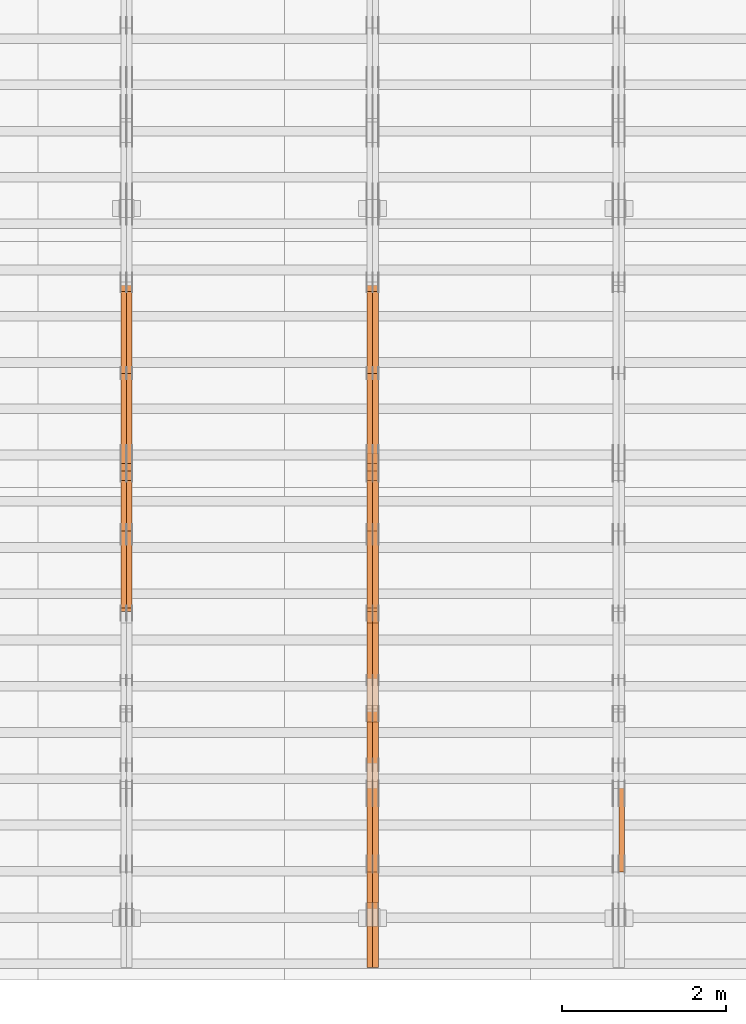
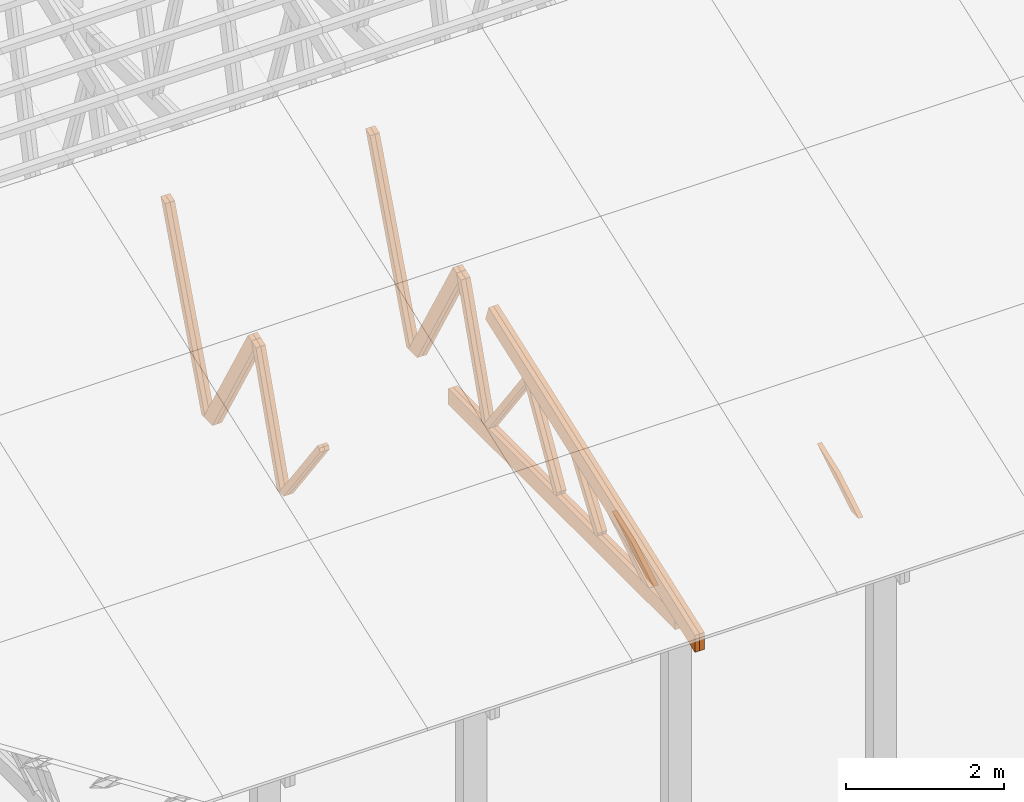
# One storey, part 46 of 189: 27 proxies.
"""IFC2X3 building model written with IfcOpenShell, lengths in millimetres."""

import ifcopenshell
import ifcopenshell.guid

model = None  # the IFC model being written
_history = None  # IfcOwnerHistory: only IFC2X3 demands one
_inside = {}  # id of a spatial element -> (the spatial element, [elements in it])
_under = {}  # id of a project, library or spatial element -> (it, [spatial elements below it])
_declared = {}  # id of a project -> (the project, [libraries it declares])
_typed = {}  # id of a type object -> (the type object, [elements of that type])
_made_of = {}  # id of a material, layer set ... -> (it, [elements and type objects made of it])


def new_model(schema):
    """Start an empty IFC model of exactly this schema.

    Asked for "IFC4X3", IfcOpenShell would pick the latest addendum, in which some entities
    have other attributes; the version numbers below select the first issue.
    IFC2X3 requires an IfcOwnerHistory on every rooted entity: one is made here for all.
    """
    global model, _history
    if schema == "IFC4X3":
        model = ifcopenshell.file(schema_version=(4, 3, 0, 0))
    else:
        model = ifcopenshell.file(schema=schema)
    _inside.clear()
    _under.clear()
    _declared.clear()
    _typed.clear()
    _made_of.clear()
    _history = None
    if model.schema == "IFC2X3":
        org = make("IfcOrganization", Name="unknown")
        user = make(
            "IfcPersonAndOrganization",
            ThePerson=make("IfcPerson", FamilyName="unknown"),
            TheOrganization=org,
        )
        app = make(
            "IfcApplication",
            ApplicationDeveloper=org,
            Version="unknown",
            ApplicationFullName="unknown",
            ApplicationIdentifier="unknown",
        )
        _history = make(
            "IfcOwnerHistory",
            OwningUser=user,
            OwningApplication=app,
            ChangeAction="ADDED",
            CreationDate=0,
        )
    return model


def make(cls, **values):
    """One entity of the class cls with the attributes given. An attribute that is None is left unset."""
    return model.create_entity(
        cls, **{name: value for name, value in values.items() if value is not None}
    )


def entity(cls, *values):
    """Any entity or typed value of the class cls, its attributes in the order of the schema. None: left unset."""
    e = model.create_entity(cls)
    for i, value in enumerate(values):
        if value is not None:
            e[i] = value
    return e


def rooted(cls, **values):
    """An entity with a GlobalId (a new one), such as an element, a storey or a relation."""
    return make(cls, GlobalId=ifcopenshell.guid.new(), OwnerHistory=_history, **values)


def si_unit(unit_type, name, prefix=None):
    """IfcSIUnit, for example si_unit("LENGTHUNIT", "METRE", prefix="MILLI")."""
    return make("IfcSIUnit", UnitType=unit_type, Prefix=prefix, Name=name)


def converted_unit(unit_type, name, factor, base, dimensions=None, offset=None):
    """IfcConversionBasedUnit, such as the inch: factor (a typed value) times the base unit."""
    return make(
        "IfcConversionBasedUnit"
        if offset is None
        else "IfcConversionBasedUnitWithOffset",
        ConversionOffset=offset,
        Dimensions=None
        if dimensions is None
        else entity("IfcDimensionalExponents", *dimensions),
        UnitType=unit_type,
        Name=name,
        ConversionFactor=make(
            "IfcMeasureWithUnit", ValueComponent=factor, UnitComponent=base
        ),
    )


def derived_unit(unit_type, elements):
    """IfcDerivedUnit: a product of units, each with its exponent."""
    return make(
        "IfcDerivedUnit",
        Elements=[
            make("IfcDerivedUnitElement", Unit=unit, Exponent=power)
            for unit, power in elements
        ],
        UnitType=unit_type,
    )


def assignment(units):
    """IfcUnitAssignment: the units of a project."""
    return None if units is None else make("IfcUnitAssignment", Units=units)


def point(xyz):
    """IfcCartesianPoint."""
    return None if xyz is None else make("IfcCartesianPoint", Coordinates=xyz)


def direction(xyz):
    """IfcDirection."""
    return None if xyz is None else make("IfcDirection", DirectionRatios=xyz)


def frame(location, z_axis=None, x_axis=None):
    """IfcAxis2Placement3D, a coordinate frame: its origin and axes. An axis left out is left unset."""
    return make(
        "IfcAxis2Placement3D",
        Location=point(location),
        Axis=direction(z_axis),
        RefDirection=direction(x_axis),
    )


def origin():
    """The frame at (0, 0, 0) with its axes left unset."""
    return frame((0.0, 0.0, 0.0))


def place(relative_to, where):
    """IfcLocalPlacement: puts the frame where relative to a parent placement (None: the world)."""
    return make(
        "IfcLocalPlacement", PlacementRelTo=relative_to, RelativePlacement=where
    )


def context(
    kind, dimensions, precision=None, world=None, true_north=None, identifier=None
):
    """IfcGeometricRepresentationContext, for example the 3D "Model" context."""
    return make(
        "IfcGeometricRepresentationContext",
        ContextIdentifier=identifier,
        ContextType=kind,
        CoordinateSpaceDimension=dimensions,
        Precision=precision,
        WorldCoordinateSystem=world,
        TrueNorth=true_north,
    )


def subcontext(parent, identifier, kind, view, scale=None):
    """IfcGeometricRepresentationSubContext, for example "Body" below "Model"."""
    return make(
        "IfcGeometricRepresentationSubContext",
        ContextIdentifier=identifier,
        ContextType=kind,
        ParentContext=parent,
        TargetScale=scale,
        TargetView=view,
    )


def project(units=None, contexts=None):
    """IfcProject with its units and contexts."""
    return rooted(
        "IfcProject",
        Name="project",
        RepresentationContexts=contexts,
        UnitsInContext=assignment(units),
    )


def spatial(cls, under=None, at=None, **own):
    """A site, building, storey or space (cls), placed at a placement, below another one or the project."""
    s = rooted(cls, ObjectPlacement=at, **own)
    if under is not None:
        _under.setdefault(under.id(), (under, []))[1].append(s)
    return s


def polyline(points):
    """IfcPolyline through the points."""
    return make("IfcPolyline", Points=[point(p) for p in points])


def outline(outer, holes=None, kind="AREA"):
    """IfcArbitraryClosedProfileDef: a profile drawn as a closed curve; with holes, ...WithVoids."""
    if holes is None:
        return make("IfcArbitraryClosedProfileDef", ProfileType=kind, OuterCurve=outer)
    return make(
        "IfcArbitraryProfileDefWithVoids",
        ProfileType=kind,
        OuterCurve=outer,
        InnerCurves=holes,
    )


def extrude(swept, where, along, depth):
    """IfcExtrudedAreaSolid: the profile swept, set in the frame where, extruded along a direction by depth."""
    return make(
        "IfcExtrudedAreaSolid",
        SweptArea=swept,
        Position=where,
        ExtrudedDirection=direction(along),
        Depth=depth,
    )


def shape(context_of_items, identifier, shape_type, items):
    """IfcShapeRepresentation: the items that make up one representation, for example the "Body"."""
    return make(
        "IfcShapeRepresentation",
        ContextOfItems=context_of_items,
        RepresentationIdentifier=identifier,
        RepresentationType=shape_type,
        Items=items,
    )


def source(mapping_origin, context_of_items, identifier, shape_type, items):
    """IfcRepresentationMap: a shape defined once, which mapped items show again and again."""
    return make(
        "IfcRepresentationMap",
        MappingOrigin=mapping_origin,
        MappedRepresentation=shape(context_of_items, identifier, shape_type, items),
    )


def transform(
    local_origin,
    x_axis=None,
    y_axis=None,
    z_axis=None,
    scale=None,
    scale2=None,
    scale3=None,
    uniform=True,
):
    """IfcCartesianTransformationOperator3D, or its non-uniform kind. x_axis, y_axis, z_axis: its Axis1, 2, 3."""
    if uniform:
        return make(
            "IfcCartesianTransformationOperator3D",
            Axis1=direction(x_axis),
            Axis2=direction(y_axis),
            LocalOrigin=point(local_origin),
            Scale=scale,
            Axis3=direction(z_axis),
        )
    return make(
        "IfcCartesianTransformationOperator3DnonUniform",
        Axis1=direction(x_axis),
        Axis2=direction(y_axis),
        LocalOrigin=point(local_origin),
        Scale=scale,
        Axis3=direction(z_axis),
        Scale2=scale2,
        Scale3=scale3,
    )


def mapped(mapping_source, mapping_target):
    """IfcMappedItem: shows the shape of a source again, moved by a transform."""
    return make(
        "IfcMappedItem", MappingSource=mapping_source, MappingTarget=mapping_target
    )


def material(Name=None, Category=None):
    """IfcMaterial."""
    return make("IfcMaterial", Name=Name, Category=Category)


def made_of(thing, what):
    """Note that an element or type object is made of a material, layer set ...; save() writes the relation."""
    if what is not None:
        _made_of.setdefault(what.id(), (what, []))[1].append(thing)
    return thing


def type_object(cls, material=None, **own):
    """A type object (cls), such as IfcWallType, which elements share."""
    return made_of(rooted(cls, **own), material)


def type_shapes(of_type, sources):
    """Give a type object the sources (RepresentationMaps) that its elements show as mapped items."""
    of_type.RepresentationMaps = sources


def element(
    cls,
    number,
    at=None,
    inside=None,
    cuts=None,
    type_object=None,
    material=None,
    context=None,
    identifier="Body",
    shape_type=None,
    held_by="IfcProductDefinitionShape",
    body=None,
    shapes=None,
    **own,
):
    """One element of the class cls, such as IfcWall. Its Tag is "e" and its number.

    at: its placement. inside: the storey or other place that contains it. cuts: it is an
    opening in that element (IfcRelVoidsElement). A single representation is given by context,
    identifier, shape_type and body (its items); several are given by shapes. held_by: the class
    of the entity that holds the representations. save() writes the other relations.
    """
    e = rooted(cls, Tag="e%d" % number, ObjectPlacement=at, **own)
    if body is not None:
        shapes = [shape(context, identifier, shape_type, body)]
    if shapes is not None:
        e.Representation = make(held_by, Representations=shapes)
    if inside is not None:
        _inside.setdefault(inside.id(), (inside, []))[1].append(e)
    if cuts is not None:
        rooted(
            "IfcRelVoidsElement", RelatingBuildingElement=cuts, RelatedOpeningElement=e
        )
    if type_object is not None:
        _typed.setdefault(type_object.id(), (type_object, []))[1].append(e)
    return made_of(e, material)


def aggregate(whole, parts):
    """IfcRelAggregates: a whole, such as a stair, and the parts it consists of."""
    return rooted("IfcRelAggregates", RelatingObject=whole, RelatedObjects=parts)


def save(model, path):
    """Write the relations noted so far, then the file.

    IfcRelAggregates (storeys below a building ...), IfcRelContainedInSpatialStructure (elements
    in a storey), IfcRelDefinesByType, IfcRelAssociatesMaterial and IfcRelDeclares: one each for
    every whole, place, type object, material and project.
    """
    for whole, parts in _under.values():
        aggregate(whole, parts)
    for where, things in _inside.values():
        rooted(
            "IfcRelContainedInSpatialStructure",
            RelatedElements=things,
            RelatingStructure=where,
        )
    for kind, things in _typed.values():
        rooted("IfcRelDefinesByType", RelatedObjects=things, RelatingType=kind)
    for what, things in _made_of.values():
        rooted("IfcRelAssociatesMaterial", RelatedObjects=things, RelatingMaterial=what)
    for by, libraries in _declared.values():
        rooted("IfcRelDeclares", RelatingContext=by, RelatedDefinitions=libraries)
    model.write(path)


model = new_model("IFC2X3")

# Units and contexts
model_context = context("Model", 3, precision=0.01, world=origin(), true_north=direction((6.12303176911189e-17, 1.0)))
body_context = subcontext(model_context, "Body", "Model", "MODEL_VIEW")
ifc_project = project(units=[si_unit("LENGTHUNIT", "METRE", prefix="MILLI"), si_unit("AREAUNIT", "SQUARE_METRE"), si_unit("VOLUMEUNIT", "CUBIC_METRE"), converted_unit("PLANEANGLEUNIT", "DEGREE", entity("IfcRatioMeasure", 0.0174532925199433), si_unit("PLANEANGLEUNIT", "RADIAN"), dimensions=[0, 0, 0, 0, 0, 0, 0]), si_unit("MASSUNIT", "GRAM", prefix="KILO"), derived_unit("MASSDENSITYUNIT", [(si_unit("MASSUNIT", "GRAM", prefix="KILO"), 1), (si_unit("LENGTHUNIT", "METRE"), -3)]), si_unit("TIMEUNIT", "SECOND"), si_unit("FREQUENCYUNIT", "HERTZ"), si_unit("THERMODYNAMICTEMPERATUREUNIT", "DEGREE_CELSIUS"), derived_unit("THERMALTRANSMITTANCEUNIT", [(si_unit("MASSUNIT", "GRAM", prefix="KILO"), 1), (si_unit("THERMODYNAMICTEMPERATUREUNIT", "KELVIN"), -1), (si_unit("TIMEUNIT", "SECOND"), -3)]), derived_unit("VOLUMETRICFLOWRATEUNIT", [(si_unit("LENGTHUNIT", "METRE"), 3), (si_unit("TIMEUNIT", "SECOND"), -1)]), si_unit("ELECTRICCURRENTUNIT", "AMPERE"), si_unit("ELECTRICVOLTAGEUNIT", "VOLT"), si_unit("POWERUNIT", "WATT"), si_unit("FORCEUNIT", "NEWTON"), si_unit("ILLUMINANCEUNIT", "LUX"), si_unit("LUMINOUSFLUXUNIT", "LUMEN"), si_unit("LUMINOUSINTENSITYUNIT", "CANDELA"), derived_unit("USERDEFINED", [(si_unit("MASSUNIT", "GRAM", prefix="KILO"), -1), (si_unit("LENGTHUNIT", "METRE"), -2), (si_unit("TIMEUNIT", "SECOND"), 3), (si_unit("LUMINOUSFLUXUNIT", "LUMEN"), 1)]), derived_unit("LINEARVELOCITYUNIT", [(si_unit("LENGTHUNIT", "METRE"), 1), (si_unit("TIMEUNIT", "SECOND"), -1)]), si_unit("PRESSUREUNIT", "PASCAL"), derived_unit("USERDEFINED", [(si_unit("LENGTHUNIT", "METRE"), -2), (si_unit("MASSUNIT", "GRAM", prefix="KILO"), 1), (si_unit("TIMEUNIT", "SECOND"), -2)])], contexts=[model_context])

# Site, building, storey
site_placement = place(None, origin())
site = spatial("IfcSite", under=ifc_project, at=site_placement, CompositionType="ELEMENT")
building_placement = place(site_placement, origin())
building = spatial("IfcBuilding", under=site, at=building_placement, CompositionType="ELEMENT")
storey_placement = place(building_placement, origin())
storey = spatial("IfcBuildingStorey", under=building, at=storey_placement, Name="Default", CompositionType="ELEMENT", Elevation=0.0)

# Proxies
ifc_material_1 = material(Name="IfcSurfaceStyle #207048")
building_element_proxy_type_1 = type_object("IfcBuildingElementProxyType", Name="T1-W12 207046", PredefinedType="NOTDEFINED", material=ifc_material_1)
shared_shape_1 = source(origin(), body_context, "Body", "SweptSolid", [
    extrude(outline(polyline([(-671.888430889784, -47.499785620702), (344.892972119224, -47.499785620702), (503.856463083211, 47.4997856207019), (-176.861004312651, 47.499785620702), (-671.888430889784, -47.499785620702)])), frame((503.857114243549, 47.5002636410509, 0.0), z_axis=(0.0, 0.0, 1.0), x_axis=(-1.0, 0.0, 0.0)), (0.0, 0.0, 1.0), 69.9999999999999),
])
type_shapes(building_element_proxy_type_1, [shared_shape_1])
proxy_1_placement = place(building_placement, frame((39300.0, 665.58122707747, 245.000076287477), z_axis=(-1.0, 0.0, 0.0), x_axis=(0.0, 0.858392121304013, 0.51299411895576)))
element("IfcBuildingElementProxy", 1, at=proxy_1_placement, inside=storey, type_object=building_element_proxy_type_1, material=ifc_material_1, Name="T1-W12", context=body_context, shape_type="MappedRepresentation", body=[
    mapped(shared_shape_1, transform((0.0, 0.0, 0.0), scale=1.0)),
])
ifc_material_2 = material(Name="IfcSurfaceStyle #193370")
building_element_proxy_type_2 = type_object("IfcBuildingElementProxyType", Name="T1-W8 193368", PredefinedType="NOTDEFINED", material=ifc_material_2)
shared_shape_2 = source(origin(), body_context, "Body", "SweptSolid", [
    extrude(outline(polyline([(-1781.70529904483, -47.500320228718), (1161.65050357787, -47.5003202287179), (1179.56135870849, 0.000731866266039397), (1140.6022069428, 47.4998218997103), (-1700.10877018433, 47.5000866914596), (-1781.70529904483, -47.500320228718)])), frame((1179.56135870869, 47.5007236522113, 0.0), z_axis=(0.0, 0.0, 1.0), x_axis=(-1.0, 3.74658825645258e-07, 0.0)), (0.0, 0.0, 1.0), 69.9999999999998),
])
type_shapes(building_element_proxy_type_2, [shared_shape_2])
proxy_2_placement = place(building_placement, frame((36300.0, 6723.5697965901, 261.758864533503), z_axis=(-1.0, 0.0, 0.0), x_axis=(0.0, 0.352814979177603, 0.93569310698963)))
element("IfcBuildingElementProxy", 2, at=proxy_2_placement, inside=storey, type_object=building_element_proxy_type_2, material=ifc_material_2, Name="T1-W8", context=body_context, shape_type="MappedRepresentation", body=[
    mapped(shared_shape_2, transform((0.0, 0.0, 0.0), scale=1.0)),
])
ifc_material_3 = material(Name="IfcSurfaceStyle #193304")
building_element_proxy_type_3 = type_object("IfcBuildingElementProxyType", Name="T1-W8 193302", PredefinedType="NOTDEFINED", material=ifc_material_3)
shared_shape_3 = source(origin(), body_context, "Body", "SweptSolid", [
    extrude(outline(polyline([(-1781.70529904483, -47.500320228718), (1161.65050357787, -47.5003202287179), (1179.56135870849, 0.000731866266039397), (1140.6022069428, 47.4998218997103), (-1700.10877018433, 47.5000866914596), (-1781.70529904483, -47.500320228718)])), frame((1179.56135870869, 47.5007236522113, 0.0), z_axis=(0.0, 0.0, 1.0), x_axis=(-1.0, 3.74658825645258e-07, 0.0)), (0.0, 0.0, 1.0), 69.9999999999998),
])
type_shapes(building_element_proxy_type_3, [shared_shape_3])
proxy_3_placement = place(building_placement, frame((36230.0, 6723.5697965901, 261.758864533503), z_axis=(-1.0, 0.0, 0.0), x_axis=(0.0, 0.352814979177603, 0.93569310698963)))
element("IfcBuildingElementProxy", 3, at=proxy_3_placement, inside=storey, type_object=building_element_proxy_type_3, material=ifc_material_3, Name="T1-W8", context=body_context, shape_type="MappedRepresentation", body=[
    mapped(shared_shape_3, transform((0.0, 0.0, 0.0), scale=1.0)),
])
ifc_material_4 = material(Name="IfcSurfaceStyle #193106")
building_element_proxy_type_4 = type_object("IfcBuildingElementProxyType", Name="T1-W2 193104", PredefinedType="NOTDEFINED", material=ifc_material_4)
shared_shape_4 = source(origin(), body_context, "Body", "SweptSolid", [
    extrude(outline(polyline([(-765.033104991319, -1130.91940266317), (-539.905732758898, -1130.91940266317), (493.678280567457, 660.584515081422), (452.144945212405, 783.697385511457), (359.115611970356, 817.556904733455), (-765.033104991319, -1130.91940266317)])), frame((904.774360566371, 97.5002668805543, 0.0), z_axis=(0.0, 0.0, 1.0), x_axis=(-0.499731715721184, 0.866180242387438, 0.0)), (0.0, 0.0, 1.0), 69.9999999999998),
])
type_shapes(building_element_proxy_type_4, [shared_shape_4])
proxy_4_placement = place(building_placement, frame((36300.0, 5635.28919163287, 2208.3400784451), z_axis=(-1.0, 0.0, 0.0), x_axis=(0.0, 0.5, -0.866025403784439)))
element("IfcBuildingElementProxy", 4, at=proxy_4_placement, inside=storey, type_object=building_element_proxy_type_4, material=ifc_material_4, Name="T1-W2", context=body_context, shape_type="MappedRepresentation", body=[
    mapped(shared_shape_4, transform((0.0, 0.0, 0.0), scale=1.0)),
])
ifc_material_5 = material(Name="IfcSurfaceStyle #193040")
building_element_proxy_type_5 = type_object("IfcBuildingElementProxyType", Name="T1-W2 193038", PredefinedType="NOTDEFINED", material=ifc_material_5)
shared_shape_5 = source(origin(), body_context, "Body", "SweptSolid", [
    extrude(outline(polyline([(-765.033104991319, -1130.91940266317), (-539.905732758898, -1130.91940266317), (493.678280567457, 660.584515081422), (452.144945212405, 783.697385511457), (359.115611970356, 817.556904733455), (-765.033104991319, -1130.91940266317)])), frame((904.774360566371, 97.5002668805543, 0.0), z_axis=(0.0, 0.0, 1.0), x_axis=(-0.499731715721184, 0.866180242387438, 0.0)), (0.0, 0.0, 1.0), 69.9999999999998),
])
type_shapes(building_element_proxy_type_5, [shared_shape_5])
proxy_5_placement = place(building_placement, frame((36230.0, 5635.28919163287, 2208.3400784451), z_axis=(-1.0, 0.0, 0.0), x_axis=(0.0, 0.5, -0.866025403784439)))
element("IfcBuildingElementProxy", 5, at=proxy_5_placement, inside=storey, type_object=building_element_proxy_type_5, material=ifc_material_5, Name="T1-W2", context=body_context, shape_type="MappedRepresentation", body=[
    mapped(shared_shape_5, transform((0.0, 0.0, 0.0), scale=1.0)),
])
ifc_material_6 = material(Name="IfcSurfaceStyle #192842")
building_element_proxy_type_6 = type_object("IfcBuildingElementProxyType", Name="T1-W9 192840", PredefinedType="NOTDEFINED", material=ifc_material_6)
shared_shape_6 = source(origin(), body_context, "Body", "SweptSolid", [
    extrude(outline(polyline([(-1227.3969292634, -47.5000382896404), (793.242467803064, -47.5000382896404), (809.267705296822, 1.0956605530188e-05), (776.329919980315, 47.5000328113376), (-1151.4431638168, 47.5000328113376), (-1227.3969292634, -47.5000382896404)])), frame((809.267705296822, 47.5000328113376, 0.0), z_axis=(0.0, 0.0, 1.0), x_axis=(-1.0, 0.0, 0.0)), (0.0, 0.0, 1.0), 69.9999999999999),
])
type_shapes(building_element_proxy_type_6, [shared_shape_6])
proxy_6_placement = place(building_placement, frame((36300.0, 4809.76380889125, 260.184242613649), z_axis=(-1.0, 0.0, 0.0), x_axis=(0.0, 0.31966811847134, 0.947529574226047)))
element("IfcBuildingElementProxy", 6, at=proxy_6_placement, inside=storey, type_object=building_element_proxy_type_6, material=ifc_material_6, Name="T1-W9", context=body_context, shape_type="MappedRepresentation", body=[
    mapped(shared_shape_6, transform((0.0, 0.0, 0.0), scale=1.0)),
])
ifc_material_7 = material(Name="IfcSurfaceStyle #192776")
building_element_proxy_type_7 = type_object("IfcBuildingElementProxyType", Name="T1-W9 192774", PredefinedType="NOTDEFINED", material=ifc_material_7)
shared_shape_7 = source(origin(), body_context, "Body", "SweptSolid", [
    extrude(outline(polyline([(-1227.3969292634, -47.5000382896404), (793.242467803064, -47.5000382896404), (809.267705296822, 1.0956605530188e-05), (776.329919980315, 47.5000328113376), (-1151.4431638168, 47.5000328113376), (-1227.3969292634, -47.5000382896404)])), frame((809.267705296822, 47.5000328113376, 0.0), z_axis=(0.0, 0.0, 1.0), x_axis=(-1.0, 0.0, 0.0)), (0.0, 0.0, 1.0), 69.9999999999999),
])
type_shapes(building_element_proxy_type_7, [shared_shape_7])
proxy_7_placement = place(building_placement, frame((36230.0, 4809.76380889125, 260.184242613649), z_axis=(-1.0, 0.0, 0.0), x_axis=(0.0, 0.31966811847134, 0.947529574226047)))
element("IfcBuildingElementProxy", 7, at=proxy_7_placement, inside=storey, type_object=building_element_proxy_type_7, material=ifc_material_7, Name="T1-W9", context=body_context, shape_type="MappedRepresentation", body=[
    mapped(shared_shape_7, transform((0.0, 0.0, 0.0), scale=1.0)),
])
ifc_material_8 = material(Name="IfcSurfaceStyle #192578")
building_element_proxy_type_8 = type_object("IfcBuildingElementProxyType", Name="T1-W10 192576", PredefinedType="NOTDEFINED", material=ifc_material_8)
shared_shape_8 = source(origin(), body_context, "Body", "SweptSolid", [
    extrude(outline(polyline([(-922.639472665691, -47.5001890573134), (629.920966338637, -47.5001890573134), (650.067737483374, 0.000694680531158376), (635.89112756682, 47.4998417170478), (-993.240358723139, 47.4998417170478), (-922.639472665691, -47.5001890573134)])), frame((650.068202545693, 47.4999816623145, 0.0), z_axis=(0.0, 0.0, 1.0), x_axis=(-1.0, 0.0, 0.0)), (0.0, 0.0, 1.0), 69.9999999999999),
])
type_shapes(building_element_proxy_type_8, [shared_shape_8])
proxy_8_placement = place(building_placement, frame((36300.0, 3874.56126239818, 1563.95828147518), z_axis=(-1.0, 0.0, 0.0), x_axis=(0.0, 0.596486092002, -0.802623412347398)))
element("IfcBuildingElementProxy", 8, at=proxy_8_placement, inside=storey, type_object=building_element_proxy_type_8, material=ifc_material_8, Name="T1-W10", context=body_context, shape_type="MappedRepresentation", body=[
    mapped(shared_shape_8, transform((0.0, 0.0, 0.0), scale=1.0)),
])
ifc_material_9 = material(Name="IfcSurfaceStyle #192512")
building_element_proxy_type_9 = type_object("IfcBuildingElementProxyType", Name="T1-W10 192510", PredefinedType="NOTDEFINED", material=ifc_material_9)
shared_shape_9 = source(origin(), body_context, "Body", "SweptSolid", [
    extrude(outline(polyline([(-922.639472665691, -47.5001890573134), (629.920966338637, -47.5001890573134), (650.067737483374, 0.000694680531158376), (635.89112756682, 47.4998417170478), (-993.240358723139, 47.4998417170478), (-922.639472665691, -47.5001890573134)])), frame((650.068202545693, 47.4999816623145, 0.0), z_axis=(0.0, 0.0, 1.0), x_axis=(-1.0, 0.0, 0.0)), (0.0, 0.0, 1.0), 69.9999999999999),
])
type_shapes(building_element_proxy_type_9, [shared_shape_9])
proxy_9_placement = place(building_placement, frame((36230.0, 3874.56126239818, 1563.95828147518), z_axis=(-1.0, 0.0, 0.0), x_axis=(0.0, 0.596486092002, -0.802623412347398)))
element("IfcBuildingElementProxy", 9, at=proxy_9_placement, inside=storey, type_object=building_element_proxy_type_9, material=ifc_material_9, Name="T1-W10", context=body_context, shape_type="MappedRepresentation", body=[
    mapped(shared_shape_9, transform((0.0, 0.0, 0.0), scale=1.0)),
])
ifc_material_10 = material(Name="IfcSurfaceStyle #192314")
building_element_proxy_type_10 = type_object("IfcBuildingElementProxyType", Name="T1-W11 192312", PredefinedType="NOTDEFINED", material=ifc_material_10)
shared_shape_10 = source(origin(), body_context, "Body", "SweptSolid", [
    extrude(outline(polyline([(593.358012843793, -552.565239103314), (742.388662259985, -552.565239103314), (-410.498749190676, 401.275038694583), (-462.246133468927, 382.44069706518), (-463.001792444175, 321.414742446865), (593.358012843793, -552.565239103314)])), frame((599.94412413079, 47.5003788877286, 0.0), z_axis=(0.0, 0.0, 1.0), x_axis=(0.770483455324544, 0.637459994879013, 0.0)), (0.0, 0.0, 1.0), 69.9999999999999),
])
type_shapes(building_element_proxy_type_10, [shared_shape_10])
proxy_10_placement = place(building_placement, frame((36300.0, 2983.26655629375, 269.034992751429), z_axis=(-1.0, 0.0, 0.0), x_axis=(0.0, 0.505995901100606, 0.862535882192379)))
element("IfcBuildingElementProxy", 10, at=proxy_10_placement, inside=storey, type_object=building_element_proxy_type_10, material=ifc_material_10, Name="T1-W11", context=body_context, shape_type="MappedRepresentation", body=[
    mapped(shared_shape_10, transform((0.0, 0.0, 0.0), scale=1.0)),
])
ifc_material_11 = material(Name="IfcSurfaceStyle #192248")
building_element_proxy_type_11 = type_object("IfcBuildingElementProxyType", Name="T1-W11 192246", PredefinedType="NOTDEFINED", material=ifc_material_11)
shared_shape_11 = source(origin(), body_context, "Body", "SweptSolid", [
    extrude(outline(polyline([(593.358012843793, -552.565239103314), (742.388662259985, -552.565239103314), (-410.498749190676, 401.275038694583), (-462.246133468927, 382.44069706518), (-463.001792444175, 321.414742446865), (593.358012843793, -552.565239103314)])), frame((599.94412413079, 47.5003788877286, 0.0), z_axis=(0.0, 0.0, 1.0), x_axis=(0.770483455324544, 0.637459994879013, 0.0)), (0.0, 0.0, 1.0), 69.9999999999999),
])
type_shapes(building_element_proxy_type_11, [shared_shape_11])
proxy_11_placement = place(building_placement, frame((36230.0, 2983.26655629375, 269.034992751429), z_axis=(-1.0, 0.0, 0.0), x_axis=(0.0, 0.505995901100606, 0.862535882192379)))
element("IfcBuildingElementProxy", 11, at=proxy_11_placement, inside=storey, type_object=building_element_proxy_type_11, material=ifc_material_11, Name="T1-W11", context=body_context, shape_type="MappedRepresentation", body=[
    mapped(shared_shape_11, transform((0.0, 0.0, 0.0), scale=1.0)),
])
ifc_material_12 = material(Name="IfcSurfaceStyle #191786")
building_element_proxy_type_12 = type_object("IfcBuildingElementProxyType", Name="T1-W13 191784", PredefinedType="NOTDEFINED", material=ifc_material_12)
shared_shape_12 = source(origin(), body_context, "Body", "SweptSolid", [
    extrude(outline(polyline([(404.740440720218, -341.48092914206), (570.336320797765, -341.48092914206), (-287.911826743206, 259.650691447848), (-342.395697357435, 239.820346030744), (-344.769237417342, 183.490820805529), (404.740440720218, -341.48092914206)])), frame((418.029573061951, 47.5005675782689, 0.0), z_axis=(0.0, 0.0, 1.0), x_axis=(0.819070847746389, 0.573692379565924, 0.0)), (0.0, 0.0, 1.0), 69.9999999999999),
])
type_shapes(building_element_proxy_type_12, [shared_shape_12])
proxy_12_placement = place(building_placement, frame((36300.0, 1951.16403402681, 272.239720286334), z_axis=(-1.0, 0.0, 0.0), x_axis=(0.0, 0.573462629043499, 0.819231721242848)))
element("IfcBuildingElementProxy", 12, at=proxy_12_placement, inside=storey, type_object=building_element_proxy_type_12, material=ifc_material_12, Name="T1-W13", context=body_context, shape_type="MappedRepresentation", body=[
    mapped(shared_shape_12, transform((0.0, 0.0, 0.0), scale=1.0)),
])
ifc_material_13 = material(Name="IfcSurfaceStyle #191720")
building_element_proxy_type_13 = type_object("IfcBuildingElementProxyType", Name="T1-W13 191718", PredefinedType="NOTDEFINED", material=ifc_material_13)
shared_shape_13 = source(origin(), body_context, "Body", "SweptSolid", [
    extrude(outline(polyline([(404.740440720218, -341.48092914206), (570.336320797765, -341.48092914206), (-287.911826743206, 259.650691447848), (-342.395697357435, 239.820346030744), (-344.769237417342, 183.490820805529), (404.740440720218, -341.48092914206)])), frame((418.029573061951, 47.5005675782689, 0.0), z_axis=(0.0, 0.0, 1.0), x_axis=(0.819070847746389, 0.573692379565924, 0.0)), (0.0, 0.0, 1.0), 69.9999999999999),
])
type_shapes(building_element_proxy_type_13, [shared_shape_13])
proxy_13_placement = place(building_placement, frame((36230.0, 1951.16403402681, 272.239720286334), z_axis=(-1.0, 0.0, 0.0), x_axis=(0.0, 0.573462629043499, 0.819231721242848)))
element("IfcBuildingElementProxy", 13, at=proxy_13_placement, inside=storey, type_object=building_element_proxy_type_13, material=ifc_material_13, Name="T1-W13", context=body_context, shape_type="MappedRepresentation", body=[
    mapped(shared_shape_13, transform((0.0, 0.0, 0.0), scale=1.0)),
])
ifc_material_14 = material(Name="IfcSurfaceStyle #191258")
building_element_proxy_type_14 = type_object("IfcBuildingElementProxyType", Name="T1-W12 191256", PredefinedType="NOTDEFINED", material=ifc_material_14)
shared_shape_14 = source(origin(), body_context, "Body", "SweptSolid", [
    extrude(outline(polyline([(-671.888430889784, -47.499785620702), (344.892972119224, -47.499785620702), (503.856463083211, 47.4997856207019), (-176.861004312651, 47.499785620702), (-671.888430889784, -47.499785620702)])), frame((503.857114243549, 47.5002636410509, 0.0), z_axis=(0.0, 0.0, 1.0), x_axis=(-1.0, 0.0, 0.0)), (0.0, 0.0, 1.0), 69.9999999999999),
])
type_shapes(building_element_proxy_type_14, [shared_shape_14])
proxy_14_placement = place(building_placement, frame((36300.0, 665.58122707747, 245.000076287477), z_axis=(-1.0, 0.0, 0.0), x_axis=(0.0, 0.858392121304013, 0.51299411895576)))
element("IfcBuildingElementProxy", 14, at=proxy_14_placement, inside=storey, type_object=building_element_proxy_type_14, material=ifc_material_14, Name="T1-W12", context=body_context, shape_type="MappedRepresentation", body=[
    mapped(shared_shape_14, transform((0.0, 0.0, 0.0), scale=1.0)),
])
ifc_material_15 = material(Name="IfcSurfaceStyle #191201")
building_element_proxy_type_15 = type_object("IfcBuildingElementProxyType", Name="T1-W12 191199", PredefinedType="NOTDEFINED", material=ifc_material_15)
shared_shape_15 = source(origin(), body_context, "Body", "SweptSolid", [
    extrude(outline(polyline([(-671.888430889784, -47.499785620702), (344.892972119224, -47.499785620702), (503.856463083211, 47.4997856207019), (-176.861004312651, 47.499785620702), (-671.888430889784, -47.499785620702)])), frame((503.857114243549, 47.5002636410509, 0.0), z_axis=(0.0, 0.0, 1.0), x_axis=(-1.0, 0.0, 0.0)), (0.0, 0.0, 1.0), 69.9999999999999),
])
type_shapes(building_element_proxy_type_15, [shared_shape_15])
proxy_15_placement = place(building_placement, frame((36230.0, 665.58122707747, 245.000076287477), z_axis=(-1.0, 0.0, 0.0), x_axis=(0.0, 0.858392121304013, 0.51299411895576)))
element("IfcBuildingElementProxy", 15, at=proxy_15_placement, inside=storey, type_object=building_element_proxy_type_15, material=ifc_material_15, Name="T1-W12", context=body_context, shape_type="MappedRepresentation", body=[
    mapped(shared_shape_15, transform((0.0, 0.0, 0.0), scale=1.0)),
])
ifc_material_16 = material(Name="IfcSurfaceStyle #190442")
building_element_proxy_type_16 = type_object("IfcBuildingElementProxyType", Name="T1-B2 190440", PredefinedType="NOTDEFINED", material=ifc_material_16)
shared_shape_16 = source(origin(), body_context, "Body", "SweptSolid", [
    extrude(outline(polyline([(-3399.385546875, -125.855288696291), (2363.08125, -125.855288696291), (2363.08125, 13.4211547851572), (2072.60859375, 119.144711303712), (-3399.385546875, 119.144711303712), (-3399.385546875, -125.855288696291)])), frame((2363.08125, 119.144711303712, 0.0), z_axis=(0.0, 0.0, 1.0), x_axis=(-1.0, 0.0, 0.0)), (0.0, 0.0, 1.0), 69.9999999999997),
])
type_shapes(building_element_proxy_type_16, [shared_shape_16])
proxy_16_placement = place(building_placement, frame((36300.0, 0.0, 245.0), z_axis=(-1.0, 0.0, 0.0), x_axis=(0.0, 1.0, 0.0)))
element("IfcBuildingElementProxy", 16, at=proxy_16_placement, inside=storey, type_object=building_element_proxy_type_16, material=ifc_material_16, Name="T1-B2", context=body_context, shape_type="MappedRepresentation", body=[
    mapped(shared_shape_16, transform((0.0, 0.0, 0.0), scale=1.0)),
])
ifc_material_17 = material(Name="IfcSurfaceStyle #190376")
building_element_proxy_type_17 = type_object("IfcBuildingElementProxyType", Name="T1-B2 190374", PredefinedType="NOTDEFINED", material=ifc_material_17)
shared_shape_17 = source(origin(), body_context, "Body", "SweptSolid", [
    extrude(outline(polyline([(-3399.385546875, -125.855288696291), (2363.08125, -125.855288696291), (2363.08125, 13.4211547851572), (2072.60859375, 119.144711303712), (-3399.385546875, 119.144711303712), (-3399.385546875, -125.855288696291)])), frame((2363.08125, 119.144711303712, 0.0), z_axis=(0.0, 0.0, 1.0), x_axis=(-1.0, 0.0, 0.0)), (0.0, 0.0, 1.0), 69.9999999999997),
])
type_shapes(building_element_proxy_type_17, [shared_shape_17])
proxy_17_placement = place(building_placement, frame((36230.0, 0.0, 245.0), z_axis=(-1.0, 0.0, 0.0), x_axis=(0.0, 1.0, 0.0)))
element("IfcBuildingElementProxy", 17, at=proxy_17_placement, inside=storey, type_object=building_element_proxy_type_17, material=ifc_material_17, Name="T1-B2", context=body_context, shape_type="MappedRepresentation", body=[
    mapped(shared_shape_17, transform((0.0, 0.0, 0.0), scale=1.0)),
])
ifc_material_18 = material(Name="IfcSurfaceStyle #190310")
building_element_proxy_type_18 = type_object("IfcBuildingElementProxyType", Name="T1-T2 190308", PredefinedType="NOTDEFINED", material=ifc_material_18)
shared_shape_18 = source(origin(), body_context, "Body", "SweptSolid", [
    extrude(outline(polyline([(-2763.12044548193, -122.499971764318), (2807.70681121203, -122.499971764318), (2807.70678531127, 122.499971764318), (-2852.29315104137, 122.499971764318), (-2763.12044548193, -122.499971764318)])), frame((2807.70684902043, 122.500023191939, 0.0), z_axis=(0.0, 0.0, 1.0), x_axis=(-1.0, 0.0, 0.0)), (0.0, 0.0, 1.0), 69.9999999999997),
])
type_shapes(building_element_proxy_type_18, [shared_shape_18])
proxy_18_placement = place(building_placement, frame((36300.0, 4818.66023370631, 1893.1253396746), z_axis=(-1.0, 0.0, 0.0), x_axis=(0.0, -0.939692620785908, -0.342020143325669)))
element("IfcBuildingElementProxy", 18, at=proxy_18_placement, inside=storey, type_object=building_element_proxy_type_18, material=ifc_material_18, Name="T1-T2", context=body_context, shape_type="MappedRepresentation", body=[
    mapped(shared_shape_18, transform((0.0, 0.0, 0.0), scale=1.0)),
])
ifc_material_19 = material(Name="IfcSurfaceStyle #190253")
building_element_proxy_type_19 = type_object("IfcBuildingElementProxyType", Name="T1-T2 190251", PredefinedType="NOTDEFINED", material=ifc_material_19)
shared_shape_19 = source(origin(), body_context, "Body", "SweptSolid", [
    extrude(outline(polyline([(-2763.12044548193, -122.499971764318), (2807.70681121203, -122.499971764318), (2807.70678531127, 122.499971764318), (-2852.29315104137, 122.499971764318), (-2763.12044548193, -122.499971764318)])), frame((2807.70684902043, 122.500023191939, 0.0), z_axis=(0.0, 0.0, 1.0), x_axis=(-1.0, 0.0, 0.0)), (0.0, 0.0, 1.0), 69.9999999999997),
])
type_shapes(building_element_proxy_type_19, [shared_shape_19])
proxy_19_placement = place(building_placement, frame((36230.0, 4818.66023370631, 1893.1253396746), z_axis=(-1.0, 0.0, 0.0), x_axis=(0.0, -0.939692620785908, -0.342020143325669)))
element("IfcBuildingElementProxy", 19, at=proxy_19_placement, inside=storey, type_object=building_element_proxy_type_19, material=ifc_material_19, Name="T1-T2", context=body_context, shape_type="MappedRepresentation", body=[
    mapped(shared_shape_19, transform((0.0, 0.0, 0.0), scale=1.0)),
])
ifc_material_20 = material(Name="IfcSurfaceStyle #177580")
building_element_proxy_type_20 = type_object("IfcBuildingElementProxyType", Name="T1-W8 177578", PredefinedType="NOTDEFINED", material=ifc_material_20)
shared_shape_20 = source(origin(), body_context, "Body", "SweptSolid", [
    extrude(outline(polyline([(-1781.70529904483, -47.500320228718), (1161.65050357787, -47.5003202287179), (1179.56135870849, 0.000731866266039397), (1140.6022069428, 47.4998218997103), (-1700.10877018433, 47.5000866914596), (-1781.70529904483, -47.500320228718)])), frame((1179.56135870869, 47.5007236522113, 0.0), z_axis=(0.0, 0.0, 1.0), x_axis=(-1.0, 3.74658825645258e-07, 0.0)), (0.0, 0.0, 1.0), 69.9999999999998),
])
type_shapes(building_element_proxy_type_20, [shared_shape_20])
proxy_20_placement = place(building_placement, frame((33300.0, 6723.5697965901, 261.758864533503), z_axis=(-1.0, 0.0, 0.0), x_axis=(0.0, 0.352814979177603, 0.93569310698963)))
element("IfcBuildingElementProxy", 20, at=proxy_20_placement, inside=storey, type_object=building_element_proxy_type_20, material=ifc_material_20, Name="T1-W8", context=body_context, shape_type="MappedRepresentation", body=[
    mapped(shared_shape_20, transform((0.0, 0.0, 0.0), scale=1.0)),
])
ifc_material_21 = material(Name="IfcSurfaceStyle #177514")
building_element_proxy_type_21 = type_object("IfcBuildingElementProxyType", Name="T1-W8 177512", PredefinedType="NOTDEFINED", material=ifc_material_21)
shared_shape_21 = source(origin(), body_context, "Body", "SweptSolid", [
    extrude(outline(polyline([(-1781.70529904483, -47.500320228718), (1161.65050357787, -47.5003202287179), (1179.56135870849, 0.000731866266039397), (1140.6022069428, 47.4998218997103), (-1700.10877018433, 47.5000866914596), (-1781.70529904483, -47.500320228718)])), frame((1179.56135870869, 47.5007236522113, 0.0), z_axis=(0.0, 0.0, 1.0), x_axis=(-1.0, 3.74658825645258e-07, 0.0)), (0.0, 0.0, 1.0), 69.9999999999998),
])
type_shapes(building_element_proxy_type_21, [shared_shape_21])
proxy_21_placement = place(building_placement, frame((33230.0, 6723.5697965901, 261.758864533503), z_axis=(-1.0, 0.0, 0.0), x_axis=(0.0, 0.352814979177603, 0.93569310698963)))
element("IfcBuildingElementProxy", 21, at=proxy_21_placement, inside=storey, type_object=building_element_proxy_type_21, material=ifc_material_21, Name="T1-W8", context=body_context, shape_type="MappedRepresentation", body=[
    mapped(shared_shape_21, transform((0.0, 0.0, 0.0), scale=1.0)),
])
ifc_material_22 = material(Name="IfcSurfaceStyle #177316")
building_element_proxy_type_22 = type_object("IfcBuildingElementProxyType", Name="T1-W2 177314", PredefinedType="NOTDEFINED", material=ifc_material_22)
shared_shape_22 = source(origin(), body_context, "Body", "SweptSolid", [
    extrude(outline(polyline([(-765.033104991319, -1130.91940266317), (-539.905732758898, -1130.91940266317), (493.678280567457, 660.584515081422), (452.144945212405, 783.697385511457), (359.115611970356, 817.556904733455), (-765.033104991319, -1130.91940266317)])), frame((904.774360566371, 97.5002668805543, 0.0), z_axis=(0.0, 0.0, 1.0), x_axis=(-0.499731715721184, 0.866180242387438, 0.0)), (0.0, 0.0, 1.0), 69.9999999999998),
])
type_shapes(building_element_proxy_type_22, [shared_shape_22])
proxy_22_placement = place(building_placement, frame((33300.0, 5635.28919163287, 2208.3400784451), z_axis=(-1.0, 0.0, 0.0), x_axis=(0.0, 0.5, -0.866025403784439)))
element("IfcBuildingElementProxy", 22, at=proxy_22_placement, inside=storey, type_object=building_element_proxy_type_22, material=ifc_material_22, Name="T1-W2", context=body_context, shape_type="MappedRepresentation", body=[
    mapped(shared_shape_22, transform((0.0, 0.0, 0.0), scale=1.0)),
])
ifc_material_23 = material(Name="IfcSurfaceStyle #177250")
building_element_proxy_type_23 = type_object("IfcBuildingElementProxyType", Name="T1-W2 177248", PredefinedType="NOTDEFINED", material=ifc_material_23)
shared_shape_23 = source(origin(), body_context, "Body", "SweptSolid", [
    extrude(outline(polyline([(-765.033104991319, -1130.91940266317), (-539.905732758898, -1130.91940266317), (493.678280567457, 660.584515081422), (452.144945212405, 783.697385511457), (359.115611970356, 817.556904733455), (-765.033104991319, -1130.91940266317)])), frame((904.774360566371, 97.5002668805543, 0.0), z_axis=(0.0, 0.0, 1.0), x_axis=(-0.499731715721184, 0.866180242387438, 0.0)), (0.0, 0.0, 1.0), 69.9999999999998),
])
type_shapes(building_element_proxy_type_23, [shared_shape_23])
proxy_23_placement = place(building_placement, frame((33230.0, 5635.28919163287, 2208.3400784451), z_axis=(-1.0, 0.0, 0.0), x_axis=(0.0, 0.5, -0.866025403784439)))
element("IfcBuildingElementProxy", 23, at=proxy_23_placement, inside=storey, type_object=building_element_proxy_type_23, material=ifc_material_23, Name="T1-W2", context=body_context, shape_type="MappedRepresentation", body=[
    mapped(shared_shape_23, transform((0.0, 0.0, 0.0), scale=1.0)),
])
ifc_material_24 = material(Name="IfcSurfaceStyle #177052")
building_element_proxy_type_24 = type_object("IfcBuildingElementProxyType", Name="T1-W9 177050", PredefinedType="NOTDEFINED", material=ifc_material_24)
shared_shape_24 = source(origin(), body_context, "Body", "SweptSolid", [
    extrude(outline(polyline([(-1227.3969292634, -47.5000382896404), (793.242467803064, -47.5000382896404), (809.267705296822, 1.0956605530188e-05), (776.329919980315, 47.5000328113376), (-1151.4431638168, 47.5000328113376), (-1227.3969292634, -47.5000382896404)])), frame((809.267705296822, 47.5000328113376, 0.0), z_axis=(0.0, 0.0, 1.0), x_axis=(-1.0, 0.0, 0.0)), (0.0, 0.0, 1.0), 69.9999999999999),
])
type_shapes(building_element_proxy_type_24, [shared_shape_24])
proxy_24_placement = place(building_placement, frame((33300.0, 4809.76380889125, 260.184242613649), z_axis=(-1.0, 0.0, 0.0), x_axis=(0.0, 0.31966811847134, 0.947529574226047)))
element("IfcBuildingElementProxy", 24, at=proxy_24_placement, inside=storey, type_object=building_element_proxy_type_24, material=ifc_material_24, Name="T1-W9", context=body_context, shape_type="MappedRepresentation", body=[
    mapped(shared_shape_24, transform((0.0, 0.0, 0.0), scale=1.0)),
])
ifc_material_25 = material(Name="IfcSurfaceStyle #176986")
building_element_proxy_type_25 = type_object("IfcBuildingElementProxyType", Name="T1-W9 176984", PredefinedType="NOTDEFINED", material=ifc_material_25)
shared_shape_25 = source(origin(), body_context, "Body", "SweptSolid", [
    extrude(outline(polyline([(-1227.3969292634, -47.5000382896404), (793.242467803064, -47.5000382896404), (809.267705296822, 1.0956605530188e-05), (776.329919980315, 47.5000328113376), (-1151.4431638168, 47.5000328113376), (-1227.3969292634, -47.5000382896404)])), frame((809.267705296822, 47.5000328113376, 0.0), z_axis=(0.0, 0.0, 1.0), x_axis=(-1.0, 0.0, 0.0)), (0.0, 0.0, 1.0), 69.9999999999999),
])
type_shapes(building_element_proxy_type_25, [shared_shape_25])
proxy_25_placement = place(building_placement, frame((33230.0, 4809.76380889125, 260.184242613649), z_axis=(-1.0, 0.0, 0.0), x_axis=(0.0, 0.31966811847134, 0.947529574226047)))
element("IfcBuildingElementProxy", 25, at=proxy_25_placement, inside=storey, type_object=building_element_proxy_type_25, material=ifc_material_25, Name="T1-W9", context=body_context, shape_type="MappedRepresentation", body=[
    mapped(shared_shape_25, transform((0.0, 0.0, 0.0), scale=1.0)),
])
ifc_material_26 = material(Name="IfcSurfaceStyle #176788")
building_element_proxy_type_26 = type_object("IfcBuildingElementProxyType", Name="T1-W10 176786", PredefinedType="NOTDEFINED", material=ifc_material_26)
shared_shape_26 = source(origin(), body_context, "Body", "SweptSolid", [
    extrude(outline(polyline([(-922.639472665691, -47.5001890573134), (629.920966338637, -47.5001890573134), (650.067737483374, 0.000694680531158376), (635.89112756682, 47.4998417170478), (-993.240358723139, 47.4998417170478), (-922.639472665691, -47.5001890573134)])), frame((650.068202545693, 47.4999816623145, 0.0), z_axis=(0.0, 0.0, 1.0), x_axis=(-1.0, 0.0, 0.0)), (0.0, 0.0, 1.0), 69.9999999999999),
])
type_shapes(building_element_proxy_type_26, [shared_shape_26])
proxy_26_placement = place(building_placement, frame((33300.0, 3874.56126239818, 1563.95828147518), z_axis=(-1.0, 0.0, 0.0), x_axis=(0.0, 0.596486092002, -0.802623412347398)))
element("IfcBuildingElementProxy", 26, at=proxy_26_placement, inside=storey, type_object=building_element_proxy_type_26, material=ifc_material_26, Name="T1-W10", context=body_context, shape_type="MappedRepresentation", body=[
    mapped(shared_shape_26, transform((0.0, 0.0, 0.0), scale=1.0)),
])
ifc_material_27 = material(Name="IfcSurfaceStyle #176722")
building_element_proxy_type_27 = type_object("IfcBuildingElementProxyType", Name="T1-W10 176720", PredefinedType="NOTDEFINED", material=ifc_material_27)
shared_shape_27 = source(origin(), body_context, "Body", "SweptSolid", [
    extrude(outline(polyline([(-922.639472665691, -47.5001890573134), (629.920966338637, -47.5001890573134), (650.067737483374, 0.000694680531158376), (635.89112756682, 47.4998417170478), (-993.240358723139, 47.4998417170478), (-922.639472665691, -47.5001890573134)])), frame((650.068202545693, 47.4999816623145, 0.0), z_axis=(0.0, 0.0, 1.0), x_axis=(-1.0, 0.0, 0.0)), (0.0, 0.0, 1.0), 69.9999999999999),
])
type_shapes(building_element_proxy_type_27, [shared_shape_27])
proxy_27_placement = place(building_placement, frame((33230.0, 3874.56126239818, 1563.95828147518), z_axis=(-1.0, 0.0, 0.0), x_axis=(0.0, 0.596486092002, -0.802623412347398)))
element("IfcBuildingElementProxy", 27, at=proxy_27_placement, inside=storey, type_object=building_element_proxy_type_27, material=ifc_material_27, Name="T1-W10", context=body_context, shape_type="MappedRepresentation", body=[
    mapped(shared_shape_27, transform((0.0, 0.0, 0.0), scale=1.0)),
])

save(model, "model.ifc")
